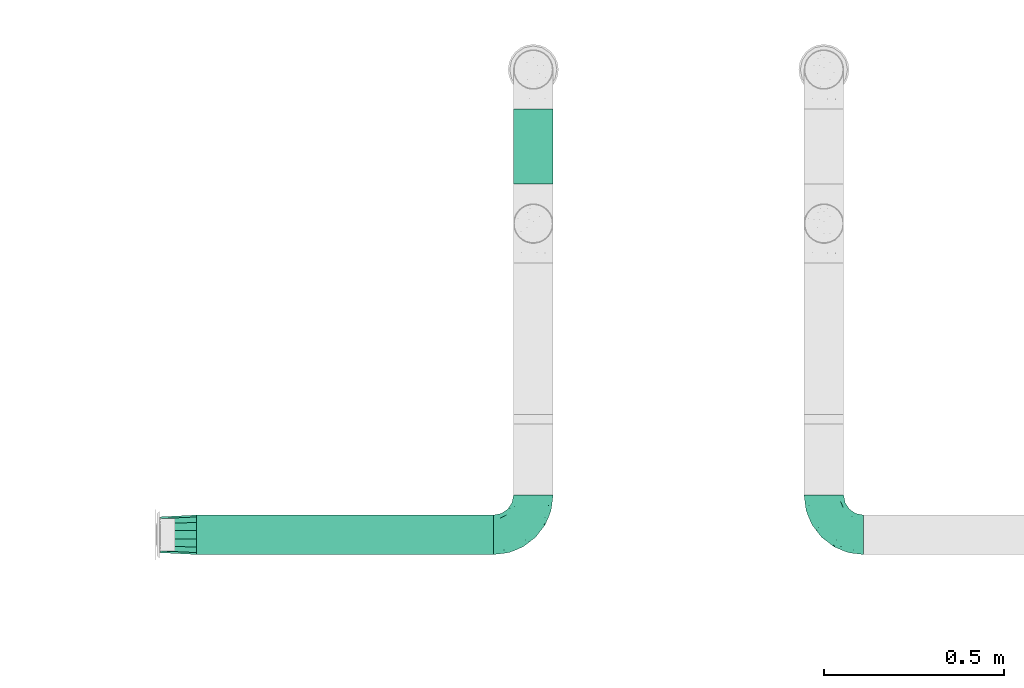
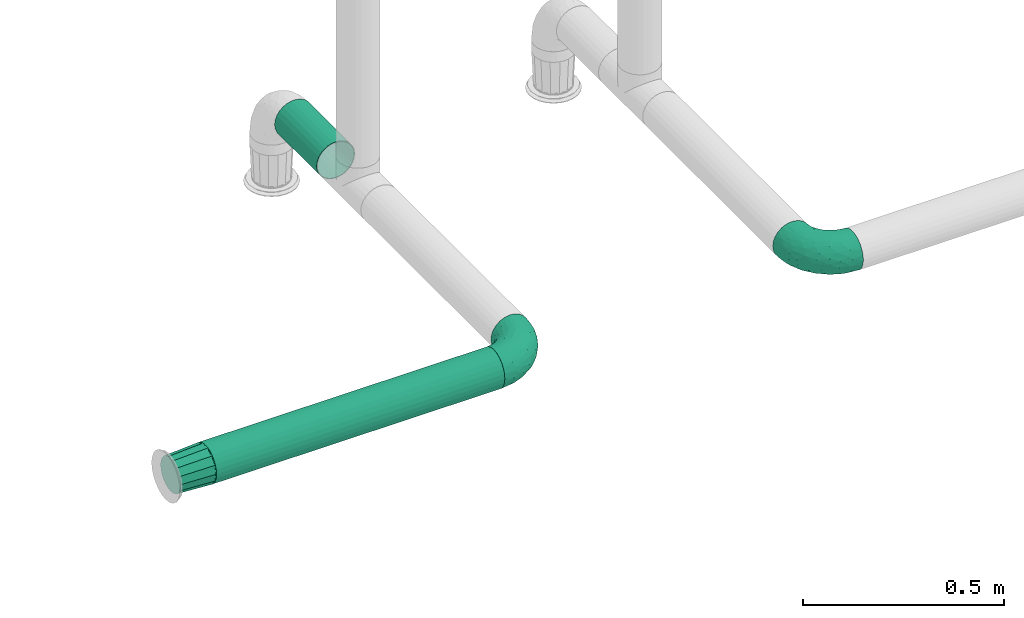
# One storey, part 8 of 103: 3 flow fittings, 2 flow segments.
"""IFC2X3 building model written with IfcOpenShell, lengths in millimetres."""

from ifc_helpers import new_model, entity, si_unit, converted_unit, derived_unit, direction, frame, origin_with_axes, origin_2d_with_axis, place, context, subcontext, project, spatial, hollow_circle, extrude, open_shell, surface_model, source, transform, mapped, material, layer, layer_set, layer_usage, type_object, element, save


model = new_model("IFC2X3")

# Units and contexts
model_context = context("Model", 3, precision=1e-05, world=origin_with_axes(), true_north=direction((0.0, 1.0)))
body_context = subcontext(model_context, "Body", "Model", "MODEL_VIEW")
ifc_project = project(units=[si_unit("AREAUNIT", "SQUARE_METRE"), si_unit("VOLUMEUNIT", "CUBIC_METRE", prefix="DECI"), si_unit("TIMEUNIT", "SECOND"), si_unit("THERMODYNAMICTEMPERATUREUNIT", "DEGREE_CELSIUS"), si_unit("PRESSUREUNIT", "PASCAL"), si_unit("MASSUNIT", "GRAM", prefix="KILO"), si_unit("LENGTHUNIT", "METRE", prefix="MILLI"), si_unit("POWERUNIT", "WATT"), si_unit("ELECTRICCURRENTUNIT", "AMPERE"), si_unit("ELECTRICVOLTAGEUNIT", "VOLT"), derived_unit("VOLUMETRICFLOWRATEUNIT", [(si_unit("VOLUMEUNIT", "CUBIC_METRE", prefix="DECI"), 1), (si_unit("TIMEUNIT", "SECOND"), -1)]), derived_unit("LINEARVELOCITYUNIT", [(si_unit("LENGTHUNIT", "METRE"), 1), (si_unit("TIMEUNIT", "SECOND"), -1)]), derived_unit("MASSDENSITYUNIT", [(si_unit("MASSUNIT", "GRAM", prefix="KILO"), 1), (si_unit("VOLUMEUNIT", "CUBIC_METRE"), -1)]), converted_unit("PLANEANGLEUNIT", "DEGREE", entity("IfcRatioMeasure", 0.01745), si_unit("PLANEANGLEUNIT", "RADIAN"), dimensions=[0, 0, 0, 0, 0, 0, 0])], contexts=[model_context])

# Site, building, storey
site_placement = place(None, origin_with_axes())
site = spatial("IfcSite", under=ifc_project, at=site_placement, CompositionType="ELEMENT")
building_placement = place(site_placement, origin_with_axes())
building = spatial("IfcBuilding", under=site, at=building_placement, Name="mc-building", CompositionType="ELEMENT")
storey_placement = place(building_placement, frame((0.0, 0.0, 5900.0), z_axis=(0.0, 0.0, 1.0), x_axis=(1.0, 0.0, 0.0)))
storey = spatial("IfcBuildingStorey", under=building, at=storey_placement, Name="3. Korrus", CompositionType="ELEMENT", Elevation=5900.0)

# Flow fittings
duct_fitting_type_1 = type_object("IfcDuctFittingType", PredefinedType="TRANSITION")
shared_shape_1 = source(origin_with_axes(), body_context, "Body", "SurfaceModel", [
    surface_model("IfcShellBasedSurfaceModel", [(0.0, 12.94095, 48.29629), (0.0, -35.35534, 35.35534), (0.0, 0.0, 50.0), (0.0, 35.35534, 35.35534), (0.0, 25.0, 43.30127), (0.0, 43.30127, 25.0), (0.0, 48.29629, 12.94095), (0.0, -12.94095, 48.29629), (0.0, -25.0, 43.30127), (0.0, -48.29629, 12.94095), (0.0, -43.30127, 25.0), (0.0, -25.0, -43.30127), (0.0, -48.29629, -12.94095), (0.0, -50.0, 0.0), (0.0, 48.29629, -12.94095), (0.0, 12.94095, -48.29629), (0.0, 43.30127, -25.0), (0.0, 35.35534, -35.35534), (0.0, 25.0, -43.30127), (0.0, -35.35534, -35.35534), (0.0, -43.30127, -25.0), (0.0, -12.94095, -48.29629), (0.0, 0.0, -50.0), (0.0, 50.0, 0.0), (100.0, -55.0, 0.0), (100.0, -12.23865, 53.62104), (100.0, -34.29194, 43.00073), (100.0, 49.55329, -23.86361), (100.0, 12.23865, 53.62104), (100.0, 34.29194, 43.00073), (100.0, 55.0, 0.0), (100.0, 49.55329, 23.86361), (100.0, -49.55329, 23.86361), (100.0, 12.23865, -53.62104), (100.0, -49.55329, -23.86361), (100.0, -34.29194, -43.00073), (100.0, 34.29194, -43.00073), (100.0, -12.23865, -53.62104), (0.0, 11.12605, 48.7464), (0.0, -11.12605, 48.7464), (0.0, 31.17449, 39.09157), (0.0, -45.04844, -21.69419), (0.0, -45.04844, 21.69419), (0.0, -31.17449, 39.09157), (0.0, 45.04844, 21.69419), (0.0, 45.04844, -21.69419), (0.0, 31.17449, -39.09157), (0.0, -31.17449, -39.09157), (0.0, -11.12605, -48.7464), (0.0, 11.12605, -48.7464), (0.0, -47.52422, -10.84709), (100.0, -41.92261, -33.43217), (0.0, -38.11147, -30.39288), (100.0, 41.92261, -33.43217), (0.0, 38.11147, -30.39288), (0.0, -21.15027, -43.91899), (100.0, -23.2653, -48.31088), (100.0, -52.32388, -11.72483), (100.0, 0.0, -53.62104), (0.0, 0.0, -48.7464), (100.0, 23.2653, -48.31088), (0.0, 21.15027, -43.91899), (100.0, 52.32388, -11.72483), (0.0, 47.52422, -10.84709), (0.0, 47.52422, 10.84709), (100.0, 41.92261, 33.43217), (0.0, 38.11147, 30.39288), (100.0, -41.92261, 33.43217), (0.0, -38.11147, 30.39288), (0.0, 21.15027, 43.91899), (100.0, 23.2653, 48.31088), (100.0, 52.32388, 11.72483), (100.0, 0.0, 53.62104), (0.0, 0.0, 48.7464), (100.0, -23.2653, 48.31088), (0.0, -21.15027, 43.91899), (100.0, -52.32388, 11.72483), (0.0, -47.52422, 10.84709), (100.0, 27.5, -47.63139), (100.0, 0.0, -55.0), (100.0, 14.23505, -53.12592), (100.0, 38.89087, -38.89087), (100.0, -27.5, -47.63139), (100.0, 47.63139, -27.5), (100.0, 53.12592, -14.23505), (100.0, -14.23505, -53.12592), (100.0, -47.63139, -27.5), (100.0, -38.89087, -38.89087), (100.0, -53.12592, -14.23505), (100.0, 53.12592, 14.23505), (100.0, 47.63139, 27.5), (100.0, 27.5, 47.63139), (100.0, 38.89087, 38.89087), (100.0, 14.23505, 53.12592), (100.0, 0.0, 55.0), (100.0, -47.63139, 27.5), (100.0, -53.12592, 14.23505), (100.0, -27.5, 47.63139), (100.0, -38.89087, 38.89087), (100.0, -14.23505, 53.12592), (98.0, 0.0, 55.0), (98.0, 14.23505, 53.12592), (98.0, 27.5, 47.63139), (98.0, 38.89087, 38.89087), (98.0, 47.63139, 27.5), (98.0, -47.63139, 27.5), (98.0, 53.12592, -14.23505), (98.0, -27.5, 47.63139), (98.0, -14.23505, 53.12592), (98.0, -38.89087, 38.89087), (98.0, -55.0, 0.0), (98.0, -53.12592, 14.23505), (98.0, 53.12592, 14.23505), (98.0, 47.63139, -27.5), (98.0, -27.5, -47.63139), (98.0, 0.0, -55.0), (98.0, 38.89087, -38.89087), (98.0, 27.5, -47.63139), (98.0, 14.23505, -53.12592), (98.0, -47.63139, -27.5), (98.0, -38.89087, -38.89087), (98.0, -53.12592, -14.23505), (98.0, -14.23505, -53.12592), (98.0, 55.0, 0.0), (2.0, 12.94095, -48.29629), (2.0, 25.0, -43.30127), (2.0, 35.35534, -35.35534), (2.0, 43.30127, -25.0), (2.0, 48.29629, -12.94095), (2.0, 0.0, -50.0), (2.0, 50.0, 0.0), (2.0, -25.0, -43.30127), (2.0, -12.94095, -48.29629), (2.0, -35.35534, -35.35534), (2.0, -48.29629, -12.94095), (2.0, -43.30127, -25.0), (2.0, -48.29629, 12.94095), (2.0, 48.29629, 12.94095), (2.0, 43.30127, 25.0), (2.0, 35.35534, 35.35534), (2.0, -35.35534, 35.35534), (2.0, 12.94095, 48.29629), (2.0, 25.0, 43.30127), (2.0, 0.0, 50.0), (2.0, -43.30127, 25.0), (2.0, -50.0, 0.0), (2.0, -12.94095, 48.29629), (2.0, -25.0, 43.30127)], [open_shell([[[0, 1, 2]], [[3, 0, 4]], [[3, 5, 6]], [[0, 3, 1]], [[6, 1, 3]], [[7, 1, 8]], [[7, 2, 1]], [[1, 9, 10]], [[9, 1, 11]], [[12, 13, 9]], [[11, 1, 6]], [[6, 14, 11]], [[15, 14, 16]], [[17, 18, 15]], [[17, 15, 16]], [[11, 14, 15]], [[12, 19, 20]], [[19, 12, 11]], [[15, 21, 11]], [[12, 9, 11]], [[22, 21, 15]], [[14, 6, 23]], [[24, 25, 26]], [[25, 27, 28]], [[29, 28, 27]], [[27, 30, 31]], [[31, 29, 27]], [[24, 26, 32]], [[33, 24, 34]], [[33, 34, 35]], [[36, 27, 33]], [[33, 27, 24]], [[35, 37, 33]], [[24, 27, 25]], [[38, 23, 39]], [[40, 23, 38]], [[41, 42, 43]], [[41, 13, 42]], [[23, 43, 39]], [[40, 44, 23]], [[41, 23, 45]], [[41, 45, 46]], [[47, 41, 48]], [[49, 48, 41]], [[41, 46, 49]], [[23, 41, 43]], [[34, 50, 41]], [[47, 51, 52]], [[45, 27, 53]], [[36, 54, 53]], [[55, 48, 56]], [[34, 57, 50]], [[57, 13, 50]], [[13, 57, 24]], [[55, 35, 47]], [[35, 51, 47]], [[51, 41, 52]], [[58, 59, 49]], [[60, 61, 46]], [[37, 59, 58]], [[62, 63, 23]], [[35, 55, 56]], [[23, 30, 62]], [[53, 54, 45]], [[48, 37, 56]], [[33, 49, 61]], [[49, 33, 58]], [[54, 36, 46]], [[63, 27, 45]], [[34, 41, 51]], [[33, 61, 60]], [[48, 59, 37]], [[27, 63, 62]], [[46, 36, 60]], [[31, 64, 44]], [[40, 65, 66]], [[42, 32, 67]], [[26, 68, 67]], [[69, 38, 70]], [[31, 71, 64]], [[71, 23, 64]], [[23, 71, 30]], [[69, 29, 40]], [[29, 65, 40]], [[65, 44, 66]], [[72, 73, 39]], [[74, 75, 43]], [[28, 73, 72]], [[76, 77, 13]], [[29, 69, 70]], [[13, 24, 76]], [[67, 68, 42]], [[38, 28, 70]], [[25, 39, 75]], [[39, 25, 72]], [[68, 26, 43]], [[77, 32, 42]], [[31, 44, 65]], [[25, 75, 74]], [[38, 73, 28]], [[32, 77, 76]], [[43, 26, 74]], [[78, 79, 80]], [[81, 82, 78]], [[82, 83, 84]], [[81, 83, 82]], [[30, 82, 84]], [[79, 82, 85]], [[79, 78, 82]], [[82, 86, 87]], [[82, 30, 86]], [[24, 88, 86]], [[86, 30, 89]], [[90, 24, 89]], [[91, 90, 92]], [[91, 93, 94]], [[90, 91, 24]], [[94, 95, 91]], [[24, 95, 96]], [[24, 91, 95]], [[94, 97, 98]], [[98, 95, 94]], [[97, 94, 99]], [[89, 24, 86]], [[100, 101, 102]], [[100, 102, 103]], [[100, 104, 105]], [[104, 100, 103]], [[106, 105, 104]], [[100, 107, 108]], [[100, 109, 107]], [[105, 110, 111]], [[109, 100, 105]], [[105, 106, 110]], [[106, 104, 112]], [[106, 113, 110]], [[113, 114, 110]], [[115, 116, 117]], [[113, 116, 115]], [[117, 118, 115]], [[119, 114, 120]], [[121, 110, 119]], [[114, 115, 122]], [[119, 110, 114]], [[115, 114, 113]], [[123, 106, 112]], [[121, 88, 110]], [[119, 86, 121]], [[82, 120, 114]], [[119, 120, 87]], [[85, 114, 122]], [[121, 86, 88]], [[88, 24, 110]], [[85, 82, 114]], [[87, 120, 82]], [[87, 86, 119]], [[79, 85, 122]], [[122, 115, 79]], [[118, 80, 115]], [[117, 78, 118]], [[83, 116, 113]], [[117, 116, 81]], [[84, 113, 106]], [[117, 81, 78]], [[78, 80, 118]], [[30, 84, 106]], [[83, 113, 84]], [[83, 81, 116]], [[123, 30, 106]], [[115, 80, 79]], [[112, 89, 123]], [[104, 90, 112]], [[91, 103, 102]], [[104, 103, 92]], [[93, 102, 101]], [[112, 90, 89]], [[89, 30, 123]], [[93, 91, 102]], [[92, 103, 91]], [[92, 90, 104]], [[94, 93, 101]], [[101, 100, 94]], [[108, 99, 100]], [[107, 97, 108]], [[95, 109, 105]], [[107, 109, 98]], [[96, 105, 111]], [[107, 98, 97]], [[97, 99, 108]], [[24, 96, 111]], [[95, 105, 96]], [[95, 98, 109]], [[110, 24, 111]], [[100, 99, 94]], [[124, 125, 126]], [[124, 126, 127]], [[124, 128, 129]], [[128, 124, 127]], [[129, 128, 130]], [[129, 131, 132]], [[129, 130, 131]], [[133, 134, 135]], [[134, 133, 131]], [[131, 136, 134]], [[131, 130, 137]], [[137, 138, 139]], [[140, 137, 139]], [[140, 139, 141]], [[141, 139, 142]], [[140, 141, 143]], [[136, 140, 144]], [[145, 134, 136]], [[140, 146, 147]], [[131, 140, 136]], [[143, 146, 140]], [[131, 137, 140]], [[12, 134, 13]], [[20, 135, 12]], [[131, 19, 11]], [[20, 19, 133]], [[132, 11, 21]], [[12, 135, 134]], [[134, 145, 13]], [[132, 131, 11]], [[133, 19, 131]], [[133, 135, 20]], [[129, 132, 21]], [[21, 22, 129]], [[15, 124, 22]], [[18, 125, 15]], [[127, 17, 16]], [[18, 17, 126]], [[128, 16, 14]], [[18, 126, 125]], [[125, 124, 15]], [[130, 128, 14]], [[127, 16, 128]], [[127, 126, 17]], [[23, 130, 14]], [[22, 124, 129]], [[6, 137, 23]], [[5, 138, 6]], [[142, 3, 4]], [[5, 3, 139]], [[141, 4, 0]], [[6, 138, 137]], [[137, 130, 23]], [[141, 142, 4]], [[139, 3, 142]], [[139, 138, 5]], [[143, 141, 0]], [[0, 2, 143]], [[7, 146, 2]], [[8, 147, 7]], [[144, 1, 10]], [[8, 1, 140]], [[136, 10, 9]], [[8, 140, 147]], [[147, 146, 7]], [[145, 136, 9]], [[144, 10, 136]], [[144, 140, 1]], [[13, 145, 9]], [[2, 146, 143]]])]),
])
flow_fitting_placement = place(storey_placement, frame((7349.07051, 3436.80698, 2345.0), z_axis=(0.0, 0.0, 1.0), x_axis=(1.0, 0.0, 0.0)))
element("IfcFlowFitting", 1, at=flow_fitting_placement, inside=storey, type_object=duct_fitting_type_1, context=body_context, shape_type="MappedRepresentation", body=[
    mapped(shared_shape_1, transform((0.0, 0.0, 0.0), scale=1.0)),
])
duct_fitting_type_2 = type_object("IfcDuctFittingType", Name="BU", PredefinedType="BEND")
shared_shape_2 = source(origin_with_axes(), body_context, "Body", "SurfaceModel", [
    surface_model("IfcShellBasedSurfaceModel", [(-110.0, 0.0, -55.0), (-110.0, -14.23505, -53.12592), (-110.0, 14.23505, -53.12592), (-110.0, 53.12592, 14.23505), (-110.0, 27.5, -47.63139), (-110.0, 38.89087, -38.89087), (-110.0, -55.0, 0.0), (-110.0, -53.12592, 14.23505), (-110.0, -38.89087, -38.89087), (-110.0, -27.5, -47.63139), (-110.0, -53.12592, -14.23505), (-110.0, -47.63139, -27.5), (-110.0, -14.23505, 53.12592), (-110.0, 14.23505, 53.12592), (-110.0, 27.5, 47.63139), (-110.0, -47.63139, 27.5), (-110.0, -38.89087, 38.89087), (-110.0, -27.5, 47.63139), (-110.0, 0.0, 55.0), (-110.0, 55.0, 0.0), (-110.0, 53.12592, -14.23505), (-110.0, 47.63139, -27.5), (-110.0, 47.63139, 27.5), (-110.0, 38.89087, 38.89087), (-14.23505, 110.0, -53.12592), (-55.0, 110.0, 0.0), (0.0, 110.0, -55.0), (-27.5, 110.0, -47.63139), (-38.89087, 110.0, -38.89087), (-47.63139, 110.0, -27.5), (38.89087, 110.0, -38.89087), (53.12592, 110.0, 14.23505), (27.5, 110.0, -47.63139), (14.23505, 110.0, -53.12592), (47.63139, 110.0, -27.5), (53.12592, 110.0, -14.23505), (55.0, 110.0, 0.0), (-53.12592, 110.0, -14.23505), (-53.12592, 110.0, 14.23505), (-47.63139, 110.0, 27.5), (-38.89087, 110.0, 38.89087), (-27.5, 110.0, 47.63139), (0.0, 110.0, 55.0), (-14.23505, 110.0, 53.12592), (38.89087, 110.0, 38.89087), (47.63139, 110.0, 27.5), (27.5, 110.0, 47.63139), (14.23505, 110.0, 53.12592), (-64.21732, 48.68956, 43.63444), (-76.6405, 38.18013, 45.55988), (-60.44912, 32.56953, 51.94617), (-76.00813, 5.38378, 55.0), (-90.15553, 11.94394, 54.09138), (-78.5998, 26.77405, 50.81338), (-70.18771, 18.55163, 54.03432), (-75.55424, 54.2118, 32.41257), (-93.27622, 45.77614, 33.48188), (-96.12334, 22.13664, 50.81337), (-21.00813, 45.34362, 55.0), (-18.36258, 70.48427, 54.04484), (-32.04182, 59.64019, 52.24446), (-63.88653, 74.77858, 17.99134), (-74.66383, 63.08407, 19.92123), (-63.60674, 66.07878, 29.97482), (-99.597, 52.72185, 18.52927), (-93.11138, 56.59448, 10.50359), (-98.21577, 57.34403, 0.0), (-53.42855, 92.60092, 21.04759), (-88.54852, 54.8376, 21.04759), (-11.86161, 90.23965, 54.10313), (-5.38378, 76.00813, 55.0), (-57.34403, 98.21577, 0.0), (-56.64619, 93.12774, 10.22088), (-45.34362, 21.00813, 55.0), (-44.60838, 44.60838, 52.13415), (-92.68484, 35.46673, 43.63443), (-22.25266, 95.40765, 50.81337), (-35.97783, 90.61597, 43.63443), (-43.70931, 69.58671, 44.47149), (-27.23711, 77.39884, 50.81337), (-57.2828, 79.3123, 24.9774), (-58.67786, 84.31125, 16.04456), (-82.93277, 60.36161, 12.91784), (-49.88337, 54.51816, 47.224), (-74.57753, 66.83759, 9.55742), (-45.35812, 94.97281, 33.48188), (-59.18663, 88.95241, 0.0), (-51.517, 78.6292, 33.48188), (-65.14788, 80.03077, 0.0), (-56.45322, 62.06476, 39.63545), (-88.95241, 59.18663, 0.0), (-71.10913, 71.10913, 0.0), (-80.03077, 65.14788, 0.0), (-94.9309, 45.36788, -33.48188), (-93.11358, 56.60141, -10.46614), (-99.64997, 52.79499, -18.30015), (-90.20425, 36.08686, -43.63443), (-79.99933, 46.56772, -37.92748), (-76.00813, 5.38378, -55.0), (-72.75364, 19.68651, -53.60527), (-45.34362, 21.00813, -55.0), (-21.91957, 65.12078, -53.85897), (-5.38378, 76.00813, -55.0), (-21.00813, 45.34362, -55.0), (-35.41876, 92.89265, -43.63443), (-91.10309, 11.02766, -54.21832), (-45.77614, 93.27622, -33.48188), (-90.50474, 23.21022, -50.81337), (-70.92854, 33.31794, -49.51754), (-78.52933, 63.35627, -11.73997), (-24.91508, 84.05606, -50.81337), (-88.78941, 54.74452, -21.04759), (-69.59921, 57.34866, -33.48187), (-73.36422, 62.46673, -22.94182), (-63.49062, 67.59111, -28.46929), (-56.59448, 93.11138, -10.50359), (-54.8376, 88.54852, -21.04759), (-54.10679, 75.85581, -32.31867), (-57.75956, 31.09612, -52.80882), (-52.72185, 99.597, -18.52927), (-12.62913, 89.46304, -53.99097), (-34.46825, 66.46123, -50.04329), (-43.9837, 43.9837, -52.42279), (-65.78527, 72.58348, -17.68796), (-70.34468, 43.65295, -44.21951), (-57.47001, 51.99467, -44.91465), (-60.72547, 82.29174, -12.88567), (-42.34915, 74.24548, -43.63444), (-57.25194, 63.5016, -38.08211), (-80.95344, 53.56991, -29.32027), (-52.32891, 4.55257, -54.0482), (32.52942, 47.13398, -30.48571), (14.88266, 20.92917, -33.7947), (14.95561, 36.05775, -42.26543), (30.24048, 70.09027, -41.7461), (19.3559, 65.35825, -48.00507), (-70.35075, -46.44478, -19.5952), (-47.13398, -32.52942, -30.48571), (-28.49299, -30.5778, -16.4009), (-4.55257, 52.32891, -54.0482), (-22.4954, 22.4954, -53.25347), (-75.47368, -11.22546, -52.60718), (-81.32209, -51.5606, -9.98467), (-80.81763, -41.84862, -32.14655), (-70.09027, -30.24048, -41.7461), (-36.05774, -14.95561, -42.26543), (-9.15831, -10.852, -27.8997), (-65.35825, -19.3559, -48.00507), (11.22546, 75.47368, -52.60718), (3.94376, 43.9333, -50.53315), (-13.39742, 13.39743, -48.13058), (-43.9333, -3.94376, -50.53315), (49.37776, 67.29486, 0.0), (41.8609, 47.82256, -9.92641), (50.20582, 74.51695, -9.9731), (18.93131, 11.7156, -17.56239), (-27.5, -32.89419, 0.0), (-1.23348, -12.25375, -12.18106), (41.84862, 80.81763, -32.14655), (35.70604, 41.31408, -20.38235), (46.44478, 70.35075, -19.5952), (32.89419, 27.5, 0.0), (6.67262, -6.67262, 0.0), (-67.29486, -49.37776, 0.0), (-50.36265, -42.95545, -9.51562), (-5.47251, 5.47251, -39.92906), (-70.35075, -46.44478, 19.5952), (-74.51695, -50.20582, 9.9731), (-41.31407, -35.70604, 20.38235), (-47.13398, -32.52942, 30.48571), (-80.81763, -41.84862, 32.14655), (-4.55257, 52.32891, 54.0482), (11.22546, 75.47368, 52.60718), (-43.9333, -3.94376, 50.53315), (-65.35825, -19.3559, 48.00507), (-36.05774, -14.95561, 42.26543), (-70.09027, -30.24048, 41.7461), (-11.7156, -18.93131, 17.56239), (30.5778, 28.49299, 16.4009), (12.25375, 1.23348, 12.18106), (51.5606, 81.32209, 9.98467), (42.95545, 50.36265, 9.51562), (-75.47368, -11.22546, 52.60718), (-52.32891, 4.55257, 54.0482), (3.94376, 43.9333, 50.53315), (-22.4954, 22.4954, 53.25347), (-13.39742, 13.39743, 48.13058), (10.852, 9.15831, 27.8997), (-20.92916, -14.88266, 33.79469), (-47.82256, -41.8609, 9.92641), (32.52942, 47.13398, 30.48571), (46.44478, 70.35075, 19.5952), (41.84862, 80.81763, 32.14655), (30.24048, 70.09027, 41.7461), (19.3559, 65.35825, 48.00507), (14.95561, 36.05775, 42.26543), (-5.47251, 5.47251, 39.92906)], [open_shell([[[0, 1, 2]], [[2, 3, 4]], [[4, 3, 5]], [[2, 6, 7]], [[8, 6, 9]], [[1, 9, 6]], [[10, 6, 11]], [[8, 11, 6]], [[6, 2, 1]], [[12, 13, 14]], [[15, 2, 7]], [[16, 17, 2]], [[2, 17, 12]], [[12, 18, 13]], [[19, 20, 3]], [[5, 3, 21]], [[20, 21, 3]], [[22, 3, 2]], [[23, 22, 2]], [[12, 14, 2]], [[2, 14, 23]], [[15, 16, 2]], [[24, 25, 26]], [[27, 25, 24]], [[25, 28, 29]], [[28, 25, 27]], [[30, 26, 31]], [[26, 30, 32]], [[32, 33, 26]], [[34, 31, 35]], [[31, 34, 30]], [[35, 31, 36]], [[29, 37, 25]], [[38, 39, 26]], [[39, 40, 26]], [[41, 42, 40]], [[42, 26, 40]], [[42, 41, 43]], [[26, 44, 45]], [[31, 26, 45]], [[26, 46, 44]], [[47, 46, 26]], [[42, 47, 26]], [[25, 38, 26]], [[48, 49, 50]], [[18, 51, 52]], [[53, 54, 50]], [[55, 56, 49]], [[56, 22, 23]], [[13, 57, 14]], [[58, 59, 60]], [[61, 62, 63]], [[3, 64, 65]], [[53, 52, 54]], [[3, 65, 66]], [[67, 39, 38]], [[56, 68, 64]], [[65, 64, 68]], [[69, 59, 70]], [[38, 71, 72]], [[73, 58, 74]], [[75, 49, 56]], [[76, 69, 43]], [[53, 57, 52]], [[77, 78, 79]], [[41, 76, 43]], [[43, 69, 42]], [[55, 68, 56]], [[23, 14, 75]], [[76, 77, 79]], [[80, 67, 81]], [[62, 82, 68]], [[60, 78, 83]], [[62, 84, 82]], [[85, 77, 40]], [[81, 67, 72]], [[86, 72, 71]], [[87, 85, 67]], [[61, 81, 88]], [[77, 41, 40]], [[78, 77, 87]], [[23, 75, 56]], [[83, 89, 48]], [[85, 40, 39]], [[62, 68, 55]], [[89, 87, 63]], [[83, 48, 50]], [[57, 75, 14]], [[49, 75, 53]], [[67, 85, 39]], [[87, 77, 85]], [[63, 62, 55]], [[89, 55, 48]], [[80, 63, 87]], [[66, 65, 90]], [[66, 19, 3]], [[84, 91, 92]], [[92, 90, 82]], [[65, 82, 90]], [[61, 84, 62]], [[92, 82, 84]], [[68, 82, 65]], [[3, 22, 64]], [[56, 64, 22]], [[38, 25, 71]], [[81, 72, 86]], [[38, 72, 67]], [[91, 61, 88]], [[80, 81, 61]], [[63, 80, 61]], [[67, 80, 87]], [[77, 76, 41]], [[79, 59, 69]], [[79, 69, 76]], [[42, 69, 70]], [[60, 59, 79]], [[58, 70, 59]], [[78, 60, 79]], [[58, 60, 74]], [[52, 57, 13]], [[75, 57, 53]], [[18, 52, 13]], [[52, 51, 54]], [[51, 73, 54]], [[50, 73, 74]], [[73, 50, 54]], [[50, 74, 83]], [[60, 83, 74]], [[89, 83, 78]], [[87, 89, 78]], [[55, 89, 63]], [[50, 49, 53]], [[55, 49, 48]], [[81, 86, 88]], [[91, 84, 61]], [[5, 21, 93]], [[90, 94, 66]], [[20, 94, 95]], [[96, 93, 97]], [[98, 99, 100]], [[96, 4, 5]], [[101, 102, 103]], [[28, 27, 104]], [[2, 105, 0]], [[104, 106, 28]], [[99, 105, 107]], [[108, 107, 96]], [[90, 109, 94]], [[107, 2, 4]], [[20, 66, 94]], [[27, 24, 110]], [[109, 111, 94]], [[112, 113, 114]], [[37, 115, 71]], [[116, 106, 117]], [[99, 118, 100]], [[116, 115, 119]], [[37, 119, 115]], [[24, 120, 110]], [[121, 110, 101]], [[119, 106, 116]], [[101, 110, 120]], [[122, 103, 100]], [[117, 123, 116]], [[124, 125, 108]], [[115, 116, 126]], [[106, 29, 28]], [[26, 102, 120]], [[127, 104, 110]], [[97, 124, 96]], [[125, 122, 118]], [[128, 127, 125]], [[96, 5, 93]], [[115, 126, 86]], [[117, 106, 127]], [[111, 113, 129]], [[95, 93, 21]], [[97, 129, 112]], [[110, 104, 27]], [[106, 104, 127]], [[96, 107, 4]], [[99, 107, 108]], [[99, 108, 118]], [[105, 99, 98]], [[112, 114, 128]], [[121, 125, 127]], [[20, 19, 66]], [[109, 90, 92]], [[94, 111, 95]], [[91, 123, 109]], [[129, 113, 112]], [[93, 95, 111]], [[21, 20, 95]], [[71, 115, 86]], [[71, 25, 37]], [[123, 91, 88]], [[126, 116, 123]], [[123, 88, 126]], [[86, 126, 88]], [[37, 29, 119]], [[106, 119, 29]], [[129, 93, 111]], [[124, 112, 125]], [[0, 105, 98]], [[107, 105, 2]], [[125, 118, 108]], [[100, 118, 122]], [[93, 129, 97]], [[113, 111, 109]], [[109, 123, 113]], [[114, 123, 117]], [[123, 114, 113]], [[128, 114, 117]], [[127, 128, 117]], [[112, 128, 125]], [[103, 122, 101]], [[110, 121, 127]], [[101, 122, 121]], [[125, 121, 122]], [[26, 120, 24]], [[101, 120, 102]], [[96, 124, 108]], [[92, 91, 109]], [[112, 124, 97]], [[100, 130, 98]], [[131, 132, 133]], [[32, 134, 135]], [[136, 137, 138]], [[139, 140, 103]], [[98, 141, 0]], [[142, 10, 136]], [[143, 144, 137]], [[6, 10, 142]], [[137, 145, 146]], [[144, 147, 145]], [[143, 136, 11]], [[11, 136, 10]], [[8, 143, 11]], [[148, 149, 139]], [[8, 9, 144]], [[9, 1, 147]], [[130, 141, 98]], [[103, 140, 100]], [[148, 135, 149]], [[150, 151, 140]], [[152, 153, 154]], [[130, 140, 151]], [[148, 26, 33]], [[147, 1, 141]], [[155, 146, 132]], [[156, 138, 157]], [[134, 30, 158]], [[150, 140, 149]], [[158, 30, 34]], [[30, 134, 32]], [[153, 159, 160]], [[131, 160, 159]], [[144, 145, 137]], [[36, 152, 154]], [[146, 138, 137]], [[155, 161, 162]], [[158, 160, 131]], [[133, 149, 135]], [[156, 163, 164]], [[163, 142, 164]], [[139, 103, 102]], [[153, 152, 161]], [[34, 35, 160]], [[162, 157, 155]], [[132, 165, 133]], [[157, 146, 155]], [[140, 130, 100]], [[141, 130, 151]], [[141, 151, 147]], [[141, 1, 0]], [[102, 26, 148]], [[140, 139, 149]], [[102, 148, 139]], [[135, 33, 32]], [[151, 150, 145]], [[9, 147, 144]], [[151, 145, 147]], [[145, 165, 146]], [[135, 148, 33]], [[133, 135, 134]], [[131, 133, 134]], [[133, 165, 150]], [[133, 150, 149]], [[145, 150, 165]], [[132, 131, 159]], [[146, 165, 132]], [[160, 158, 34]], [[134, 158, 131]], [[144, 143, 8]], [[136, 143, 137]], [[155, 153, 161]], [[154, 153, 160]], [[153, 155, 159]], [[132, 159, 155]], [[160, 35, 154]], [[36, 154, 35]], [[164, 136, 138]], [[6, 142, 163]], [[136, 164, 142]], [[156, 164, 138]], [[156, 157, 162]], [[146, 157, 138]], [[15, 7, 166]], [[6, 163, 167]], [[168, 169, 166]], [[166, 169, 170]], [[171, 172, 70]], [[173, 174, 175]], [[17, 176, 174]], [[177, 156, 162]], [[176, 16, 170]], [[170, 16, 15]], [[161, 178, 179]], [[152, 180, 181]], [[182, 173, 183]], [[18, 12, 182]], [[184, 185, 186]], [[183, 185, 73]], [[183, 73, 51]], [[177, 187, 188]], [[189, 168, 166]], [[187, 178, 190]], [[16, 176, 17]], [[161, 152, 181]], [[45, 191, 31]], [[45, 44, 192]], [[192, 191, 45]], [[180, 36, 31]], [[193, 194, 195]], [[46, 47, 194]], [[193, 195, 190]], [[193, 44, 46]], [[172, 42, 70]], [[185, 58, 73]], [[189, 163, 156]], [[163, 189, 167]], [[70, 58, 171]], [[184, 171, 185]], [[169, 188, 175]], [[180, 31, 191]], [[192, 193, 190]], [[191, 190, 178]], [[182, 174, 173]], [[194, 47, 172]], [[190, 195, 187]], [[186, 185, 173]], [[162, 179, 177]], [[188, 196, 175]], [[179, 187, 177]], [[185, 171, 58]], [[172, 171, 184]], [[172, 184, 194]], [[172, 47, 42]], [[51, 18, 182]], [[185, 183, 173]], [[51, 182, 183]], [[174, 12, 17]], [[184, 186, 195]], [[46, 194, 193]], [[184, 195, 194]], [[195, 196, 187]], [[174, 182, 12]], [[175, 174, 176]], [[169, 175, 176]], [[175, 196, 186]], [[175, 186, 173]], [[195, 186, 196]], [[188, 169, 168]], [[187, 196, 188]], [[166, 170, 15]], [[176, 170, 169]], [[193, 192, 44]], [[191, 192, 190]], [[177, 189, 156]], [[167, 189, 166]], [[189, 177, 168]], [[188, 168, 177]], [[166, 7, 167]], [[6, 167, 7]], [[181, 191, 178]], [[36, 180, 152]], [[191, 181, 180]], [[161, 181, 178]], [[161, 179, 162]], [[187, 179, 178]]])]),
])
for number, where, z_axis, x_axis, name in (
    (2, (9194.13313, 3436.80698, 2345.0), (0.0, 0.0, 1.0), (0.0, -1.0, 0.0), "BU"),
    (3, (8385.80789, 3436.80698, 2345.0), (0.0, 0.0, 1.0), (1.0, 0.0, 0.0), "BU"),
):
    element("IfcFlowFitting", number, at=place(storey_placement, frame(where, z_axis=z_axis, x_axis=x_axis)), inside=storey, type_object=duct_fitting_type_2, Name=name, context=body_context, shape_type="MappedRepresentation", body=[
        mapped(shared_shape_2, transform((0.0, 0.0, 0.0), scale=1.0)),
    ])

# Flow segments
ifc_material = material(Name="FZ1")
ifc_layer = layer(ifc_material, 0.0)
ifc_layer_set = layer_set([ifc_layer], Name="FZ1")
ifc_layer_usage = layer_usage(ifc_layer_set, "AXIS1", "POSITIVE", 0.0)
duct_segment_type_1 = type_object("IfcDuctSegmentType", Name="Safe", PredefinedType="RIGIDSEGMENT")
shared_shape_3 = source(origin_with_axes(), body_context, "Body", "SweptSolid", [
    extrude(hollow_circle(Radius=55.0, WallThickness=2.0, at=origin_2d_with_axis()), frame((0.0, 0.0, 0.0), z_axis=(1.0, 0.0, 0.0), x_axis=(0.0, 1.0, 0.0)), (0.0, 0.0, 1.0), 208.6),
])
flow_segment_1_placement = place(storey_placement, frame((8385.80789, 4412.28735, 2345.0), z_axis=(0.0, 0.0, 1.0), x_axis=(0.0, 1.0, 0.0)))
element("IfcFlowSegment", 4, at=flow_segment_1_placement, inside=storey, type_object=duct_segment_type_1, material=ifc_layer_usage, Name="Safe", context=body_context, shape_type="MappedRepresentation", body=[
    mapped(shared_shape_3, transform((0.0, 0.0, 0.0), scale=1.0)),
])
duct_segment_type_2 = type_object("IfcDuctSegmentType", PredefinedType="RIGIDSEGMENT")
shared_shape_4 = source(origin_with_axes(), body_context, "Body", "SweptSolid", [
    extrude(hollow_circle(Radius=55.0, WallThickness=2.0, at=origin_2d_with_axis()), frame((0.0, 0.0, 0.0), z_axis=(1.0, 0.0, 0.0), x_axis=(0.0, 1.0, 0.0)), (0.0, 0.0, 1.0), 826.7),
])
flow_segment_2_placement = place(storey_placement, frame((7449.07051, 3436.80698, 2345.0), z_axis=(0.0, 0.0, 1.0), x_axis=(1.0, 0.0, 0.0)))
element("IfcFlowSegment", 5, at=flow_segment_2_placement, inside=storey, type_object=duct_segment_type_2, material=ifc_layer_usage, context=body_context, shape_type="MappedRepresentation", body=[
    mapped(shared_shape_4, transform((0.0, 0.0, 0.0), scale=1.0)),
])

save(model, "model.ifc")
